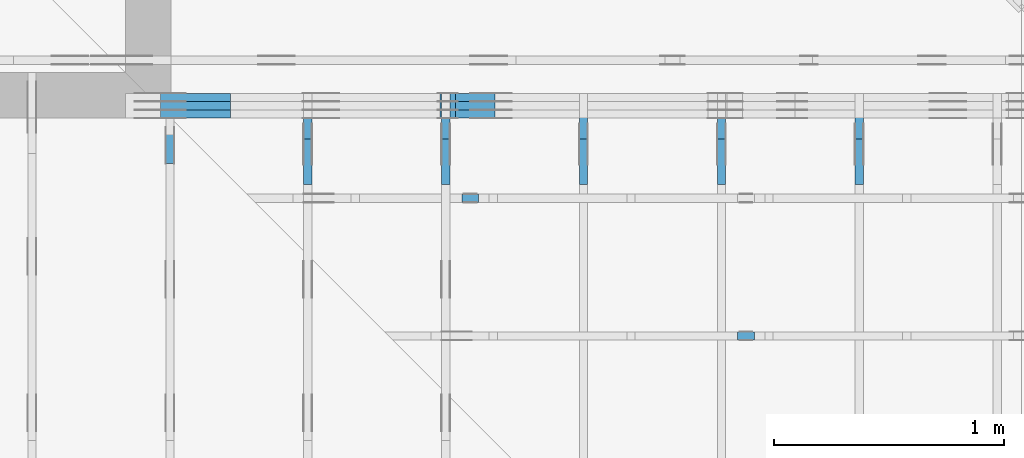
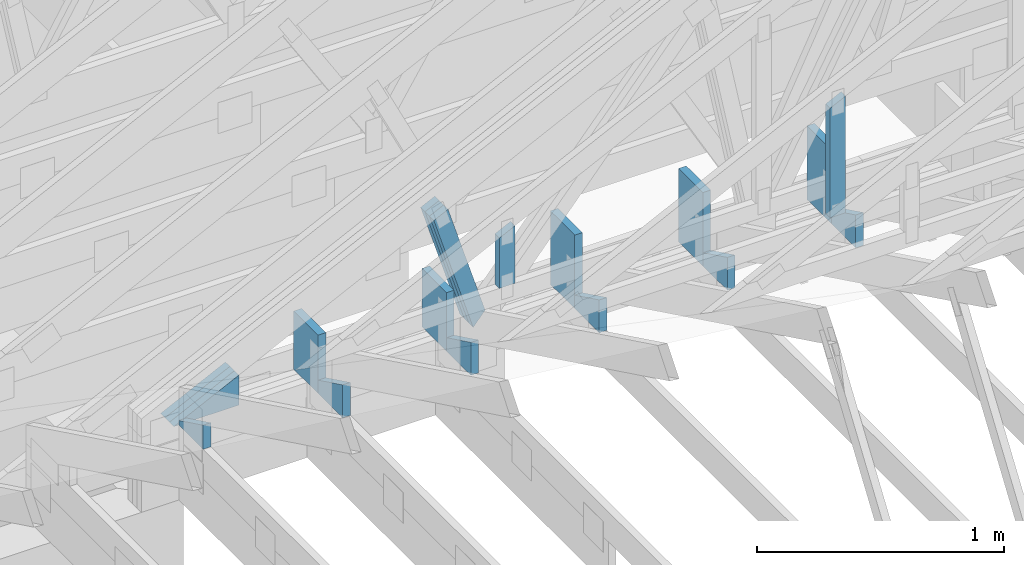
# One storey, part 45 of 159: 19 members, 9 elements without a shape of their own.
"""IFC2X3 building model written with IfcOpenShell, lengths in millimetres."""

from ifc_helpers import new_model, si_unit, frame, origin, origin_with_axes, origin_2d, place, context, project, spatial, faceted_brep, element, aggregate, save


model = new_model("IFC2X3")

# Units and contexts
model_context = context("Model", 3, precision=1e-05, world=origin())
plan_context = context("Plan", 2, precision=1e-05, world=origin_2d())
ifc_project = project(units=[si_unit("LENGTHUNIT", "METRE", prefix="MILLI"), si_unit("AREAUNIT", "SQUARE_METRE"), si_unit("VOLUMEUNIT", "CUBIC_METRE"), si_unit("SOLIDANGLEUNIT", "STERADIAN"), si_unit("PLANEANGLEUNIT", "RADIAN"), si_unit("MASSUNIT", "GRAM"), si_unit("TIMEUNIT", "SECOND"), si_unit("THERMODYNAMICTEMPERATUREUNIT", "DEGREE_CELSIUS"), si_unit("LUMINOUSINTENSITYUNIT", "LUMEN")], contexts=[model_context, plan_context])

# Site, building, storey
site_placement = place(None, origin_with_axes())
site = spatial("IfcSite", under=ifc_project, at=site_placement, CompositionType="ELEMENT")
building_placement = place(site_placement, origin_with_axes())
building = spatial("IfcBuilding", under=site, at=building_placement, Name="Plan 1", CompositionType="ELEMENT")
storey_placement = place(building_placement, origin_with_axes())
storey = spatial("IfcBuildingStorey", under=building, at=storey_placement, Name="Etasje 1", CompositionType="ELEMENT", Elevation=0.0)

# Assembly, members
assembly_1_placement = place(storey_placement, frame((10700.012663101485, 8801.999999990367, 0.0), z_axis=(0.0, -1.0, 6.123031769111886e-17), x_axis=(1.0, 0.0, 0.0)))
assembly_1 = element("IfcElementAssembly", 1, at=assembly_1_placement, inside=storey, Name="T8 (1)", AssemblyPlace="FACTORY", PredefinedType="TRUSS")
member_1_placement = place(assembly_1_placement, frame((152.23972507752478, 371.0, -36.0), z_axis=(0.0, 0.0, 1.0), x_axis=(1.0, 0.0, 0.0)))
member_1 = element("IfcMember", 2, at=member_1_placement, Name="T8-KI4", context=model_context, shape_type="Brep", body=[
    faceted_brep([(303.4449673052877, 148.0, 36.0), (5.757436156272888e-06, 0.0, 36.0), (303.4449673052877, 0.0, 36.0), (303.4449673052877, 148.0, 0.0), (303.4449673052877, 0.0, 0.0), (5.757436156272888e-06, 0.0, 0.0), (0.0, 0.0, 0.0), (9.662977650426896e-16, -1.9812040197761635e-15, 36.0), (303.444968553682, 147.99999999999997, 36.0), (303.444968553682, 147.99999999999997, -2.6180736086187996e-30), (303.4449685537356, -5.574009547895041e-14, 3.412983754309432e-30), (303.4449685537356, -5.353580404207013e-14, 36.0), (4.049083948919771e-31, 2.204291436880279e-15, 36.0), (0.0, 0.0, 0.0), (303.4449685537356, 148.0, 3.281661365719409e-27), (303.4449685537356, 148.0, 36.0), (303.4449685537356, 0.0, 36.0), (303.4449685537356, 0.0, 0.0)], [[[0, 1, 2]], [[3, 4, 5]], [[6, 7, 8, 9]], [[10, 11, 12, 13]], [[14, 15, 16, 17]]]),
])
member_2_placement = place(assembly_1_placement, frame((152.23972507752478, 371.0, -72.0), z_axis=(0.0, 0.0, 1.0), x_axis=(1.0, 0.0, 0.0)))
member_2 = element("IfcMember", 3, at=member_2_placement, Name="T8-KI4", context=model_context, shape_type="Brep", body=[
    faceted_brep([(303.4449673052877, 148.0, 36.0), (5.757436156272888e-06, 0.0, 36.0), (303.4449673052877, 0.0, 36.0), (303.4449673052877, 148.0, 0.0), (303.4449673052877, 0.0, 0.0), (5.757436156272888e-06, 0.0, 0.0), (0.0, 0.0, 0.0), (9.662977650426896e-16, -1.9812040197761635e-15, 36.0), (303.444968553682, 147.99999999999997, 36.0), (303.444968553682, 147.99999999999997, -2.6180736086187996e-30), (303.4449685537356, -5.574009547895041e-14, 3.412983754309432e-30), (303.4449685537356, -5.353580404207013e-14, 36.0), (4.049083948919771e-31, 2.204291436880279e-15, 36.0), (0.0, 0.0, 0.0), (303.4449685537356, 148.0, 3.281661365719409e-27), (303.4449685537356, 148.0, 36.0), (303.4449685537356, 0.0, 36.0), (303.4449685537356, 0.0, 0.0)], [[[0, 1, 2]], [[3, 4, 5]], [[6, 7, 8, 9]], [[10, 11, 12, 13]], [[14, 15, 16, 17]]]),
])
member_3_placement = place(assembly_1_placement, frame((152.23972507752478, 371.0, -108.0), z_axis=(0.0, 0.0, 1.0), x_axis=(1.0, 0.0, 0.0)))
member_3 = element("IfcMember", 4, at=member_3_placement, Name="T8-KI4", context=model_context, shape_type="Brep", body=[
    faceted_brep([(303.4449673052877, 148.0, 36.0), (5.757436156272888e-06, 0.0, 36.0), (303.4449673052877, 0.0, 36.0), (303.4449673052877, 148.0, 0.0), (303.4449673052877, 0.0, 0.0), (5.757436156272888e-06, 0.0, 0.0), (0.0, 0.0, 0.0), (9.662977650426896e-16, -1.9812040197761635e-15, 36.0), (303.444968553682, 147.99999999999997, 36.0), (303.444968553682, 147.99999999999997, -2.6180736086187996e-30), (303.4449685537356, -5.574009547895041e-14, 3.412983754309432e-30), (303.4449685537356, -5.353580404207013e-14, 36.0), (4.049083948919771e-31, 2.204291436880279e-15, 36.0), (0.0, 0.0, 0.0), (303.4449685537356, 148.0, 3.281661365719409e-27), (303.4449685537356, 148.0, 36.0), (303.4449685537356, 0.0, 36.0), (303.4449685537356, 0.0, 0.0)], [[[0, 1, 2]], [[3, 4, 5]], [[6, 7, 8, 9]], [[10, 11, 12, 13]], [[14, 15, 16, 17]]]),
])
member_4_placement = place(assembly_1_placement, frame((1364.9619327312275, 974.8732628505372, -36.00000000000001), z_axis=(0.0, 0.0, 1.0), x_axis=(0.2961414573045144, -0.9551440924099143, 0.0)))
member_4 = element("IfcMember", 5, at=member_4_placement, Name="T8-D67", context=model_context, shape_type="Brep", body=[
    faceted_brep([(585.6447533994713, 73.00007706554379, 36.0), (3.7655692040061695e-06, 73.00007706554379, 36.0), (11.2670859511461, 0.0, 36.0), (632.2326779148378, 0.0, 36.0), (3.7655692040061695e-06, 73.00007706554379, 4.611339972983827e-22), (585.6447533994713, 73.00007706554379, 7.171842860957318e-14), (632.2326779148378, 0.0, 7.74236154468647e-14), (11.2670859511461, 0.0, 1.3797745044836358e-15), (11.26711467820826, 3.2846568956523825e-05, -9.860761315262648e-32), (11.267114678208262, 3.2846568956967914e-05, 36.0), (3.197442310920451e-14, 73.00023531536866, 36.0), (3.019806626980426e-14, 73.00023531536866, -1.9721522630525295e-30), (632.2326729089058, 0.00013408096902131113, 2.771038273103004e-29), (632.2326729089058, 0.00013408096902351542, 36.0), (11.26711467820826, 3.2846568950440936e-05, 36.0), (11.26711467820826, 3.2846568948236644e-05, 4.938306310742308e-31), (585.644755694868, 73.00013408096831, 6.310887241768095e-30), (585.644755694868, 73.00013408096831, 36.0), (632.2326729089058, 0.00013408096947387094, 36.0), (632.2326729089058, 0.00013408096947387094, 0.0), (0.0, 73.00023531536863, 1.8541662651750408e-44), (0.0, 73.00023531536863, 36.0), (585.644755694868, 73.00013408096848, 36.0), (585.644755694868, 73.00013408096848, 8.677469096903521e-30)], [[[0, 1, 2, 3]], [[4, 5, 6, 7]], [[8, 9, 10, 11]], [[12, 13, 14, 15]], [[16, 17, 18, 19]], [[20, 21, 22, 23]]]),
])
member_5_placement = place(assembly_1_placement, frame((1364.9619327312275, 974.8732628505372, -72.00000000000001), z_axis=(0.0, 0.0, 1.0), x_axis=(0.2961414573045144, -0.9551440924099143, 0.0)))
member_5 = element("IfcMember", 6, at=member_5_placement, Name="T8-D67", context=model_context, shape_type="Brep", body=[
    faceted_brep([(585.6447533994713, 73.00007706554379, 36.0), (3.7655692040061695e-06, 73.00007706554379, 36.0), (11.2670859511461, 0.0, 36.0), (632.2326779148378, 0.0, 36.0), (3.7655692040061695e-06, 73.00007706554379, 4.611339972983827e-22), (585.6447533994713, 73.00007706554379, 7.171842860957318e-14), (632.2326779148378, 0.0, 7.74236154468647e-14), (11.2670859511461, 0.0, 1.3797745044836358e-15), (11.26711467820826, 3.2846568956523825e-05, -9.860761315262648e-32), (11.267114678208262, 3.2846568956967914e-05, 36.0), (3.197442310920451e-14, 73.00023531536866, 36.0), (3.019806626980426e-14, 73.00023531536866, -1.9721522630525295e-30), (632.2326729089058, 0.00013408096902131113, 2.771038273103004e-29), (632.2326729089058, 0.00013408096902351542, 36.0), (11.26711467820826, 3.2846568950440936e-05, 36.0), (11.26711467820826, 3.2846568948236644e-05, 4.938306310742308e-31), (585.644755694868, 73.00013408096831, 6.310887241768095e-30), (585.644755694868, 73.00013408096831, 36.0), (632.2326729089058, 0.00013408096947387094, 36.0), (632.2326729089058, 0.00013408096947387094, 0.0), (0.0, 73.00023531536863, 1.8541662651750408e-44), (0.0, 73.00023531536863, 36.0), (585.644755694868, 73.00013408096848, 36.0), (585.644755694868, 73.00013408096848, 8.677469096903521e-30)], [[[0, 1, 2, 3]], [[4, 5, 6, 7]], [[8, 9, 10, 11]], [[12, 13, 14, 15]], [[16, 17, 18, 19]], [[20, 21, 22, 23]]]),
])
member_6_placement = place(assembly_1_placement, frame((1364.9619327312275, 974.8732628505372, -108.00000000000001), z_axis=(0.0, 0.0, 1.0), x_axis=(0.2961414573045144, -0.9551440924099143, 0.0)))
member_6 = element("IfcMember", 7, at=member_6_placement, Name="T8-D67", context=model_context, shape_type="Brep", body=[
    faceted_brep([(585.6447533994713, 73.00007706554379, 36.0), (3.7655692040061695e-06, 73.00007706554379, 36.0), (11.2670859511461, 0.0, 36.0), (632.2326779148378, 0.0, 36.0), (3.7655692040061695e-06, 73.00007706554379, 4.611339972983827e-22), (585.6447533994713, 73.00007706554379, 7.171842860957318e-14), (632.2326779148378, 0.0, 7.74236154468647e-14), (11.2670859511461, 0.0, 1.3797745044836358e-15), (11.26711467820826, 3.2846568956523825e-05, -9.860761315262648e-32), (11.267114678208262, 3.2846568956967914e-05, 36.0), (3.197442310920451e-14, 73.00023531536866, 36.0), (3.019806626980426e-14, 73.00023531536866, -1.9721522630525295e-30), (632.2326729089058, 0.00013408096902131113, 2.771038273103004e-29), (632.2326729089058, 0.00013408096902351542, 36.0), (11.26711467820826, 3.2846568950440936e-05, 36.0), (11.26711467820826, 3.2846568948236644e-05, 4.938306310742308e-31), (585.644755694868, 73.00013408096831, 6.310887241768095e-30), (585.644755694868, 73.00013408096831, 36.0), (632.2326729089058, 0.00013408096947387094, 36.0), (632.2326729089058, 0.00013408096947387094, 0.0), (0.0, 73.00023531536863, 1.8541662651750408e-44), (0.0, 73.00023531536863, 36.0), (585.644755694868, 73.00013408096848, 36.0), (585.644755694868, 73.00013408096848, 8.677469096903521e-30)], [[[0, 1, 2, 3]], [[4, 5, 6, 7]], [[8, 9, 10, 11]], [[12, 13, 14, 15]], [[16, 17, 18, 19]], [[20, 21, 22, 23]]]),
])
aggregate(assembly_1, [member_1, member_2, member_3, member_4, member_5, member_6])

assembly_2_placement = place(storey_placement, frame((13875.022261404752, -699.9989301294836, 1.1021457184401395e-15), z_axis=(-1.0, 1.836909530733566e-16, 6.123031769111886e-17), x_axis=(-1.836909530733566e-16, -1.0, 0.0)))
assembly_2 = element("IfcElementAssembly", 8, at=assembly_2_placement, inside=storey, Name="T6 (101)", AssemblyPlace="FACTORY", PredefinedType="TRUSS")
member_7_placement = place(assembly_2_placement, frame((-9411.99893013318, 371.0, -36.0), z_axis=(0.0, 0.0, 1.0), x_axis=(-2.6074085653169515e-12, 1.0, 0.0)))
member_7 = element("IfcMember", 9, at=member_7_placement, Name="T6-S1", context=model_context, shape_type="Brep", body=[
    faceted_brep([(363.47723388723495, 198.0000933033716, 36.0), (5.162519300938584e-10, 198.0000933033716, 36.0), (0.0, 9.330431930720806e-05, 36.0), (363.4772338867187, 9.330431930720806e-05, 36.0), (5.162519300938584e-10, 198.0000933033716, 6.322053937660047e-26), (363.47723388723495, 198.0000933033716, 4.4511653008809024e-14), (363.4772338867187, 9.330431930720806e-05, 4.45116530087458e-14), (0.0, 9.330431930720806e-05, 0.0), (0.0, 0.0, 0.0), (2.204291436880279e-15, -5.7474038303501e-27, 36.0), (5.162615062011267e-10, 198.0, 36.0), (5.162593019096898e-10, 198.0, -4.513786253158592e-31), (363.47721516495375, 6.308078123434283e-08, -2.921223515766118e-30), (363.47721516495375, 6.308078343863427e-08, 36.0), (-3.825505976859566e-25, 2.204291436880279e-15, 36.0), (0.0, 0.0, 0.0), (363.47721516495375, 198.0000000612181, -3.16080787503955e-26), (363.47721516495375, 198.0000000612181, 36.0), (363.47721516495375, 6.308073352556676e-08, 36.0), (363.47721516495375, 6.308073352556676e-08, 0.0), (5.162519300938584e-10, 198.0, 0.0), (5.162519300938584e-10, 198.0, 36.0), (363.47721516547, 198.0000000612181, 36.0), (363.47721516547, 198.0000000612181, -1.5777218104420236e-30)], [[[0, 1, 2, 3]], [[4, 5, 6, 7]], [[8, 9, 10, 11]], [[12, 13, 14, 15]], [[16, 17, 18, 19]], [[20, 21, 22, 23]]]),
])
member_8_placement = place(assembly_2_placement, frame((-9213.998930133188, 371.0, -36.0), z_axis=(0.0, 0.0, 1.0), x_axis=(-1.7615569541788202e-10, 1.0, 0.0)))
member_8 = element("IfcMember", 10, at=member_8_placement, Name="T6-S5", context=model_context, shape_type="Brep", body=[
    faceted_brep([(66.21466067941009, 198.00009329264867, 36.0), (3.4878837595897494e-08, 198.00009329264867, 36.0), (0.0, 9.330431203125045e-05, 36.0), (162.7857055664063, 9.330431203125045e-05, 36.0), (3.4878837595897494e-08, 198.00009329264867, 4.271284613387488e-24), (66.21466067941009, 198.00009329264867, 8.108689418419832e-15), (162.7857055664063, 9.330431203125045e-05, 1.9934840934807988e-14), (0.0, 9.330431203125045e-05, 0.0), (-2.605355528885784e-24, 6.255140760913491e-08, 1.5952674669991638e-40), (2.2042914342749235e-15, 6.255140760913491e-08, 36.0), (3.487882230300644e-08, 198.00000006253686, 36.0), (3.4878820098715006e-08, 198.00000006253686, 1.071358042460672e-30), (162.78571493316844, -3.9667248731015275e-14, 2.4288382424236155e-30), (162.78571493316844, -3.7462957294134996e-14, 36.0), (8.470130163630552e-25, 6.255140981342635e-08, 36.0), (0.0, 6.255140760913491e-08, 0.0), (66.21466011511593, 198.0, 0.0), (66.21466011511593, 198.0, 36.0), (162.78571493316844, 1.4210854715202004e-14, 36.0), (162.78571493316846, 1.4210854715202004e-14, 1.5777218104420236e-30), (3.4878837595897494e-08, 198.00000006253686, 0.0), (3.4878837595897494e-08, 198.00000006253686, 36.0), (66.21466011511592, 198.0, 36.0), (66.21466011511592, 198.0, 0.0)], [[[0, 1, 2, 3]], [[4, 5, 6, 7]], [[8, 9, 10, 11]], [[12, 13, 14, 15]], [[16, 17, 18, 19]], [[20, 21, 22, 23]]]),
])
aggregate(assembly_2, [member_7, member_8])

assembly_3_placement = place(storey_placement, frame((13275.022261404752, -699.9989301294836, 1.1021457184401395e-15), z_axis=(-1.0, 1.836909530733566e-16, 6.123031769111886e-17), x_axis=(-1.836909530733566e-16, -1.0, 0.0)))
assembly_3 = element("IfcElementAssembly", 11, at=assembly_3_placement, inside=storey, Name="T6 (100)", AssemblyPlace="FACTORY", PredefinedType="TRUSS")
member_9_placement = place(assembly_3_placement, frame((-9411.99893013318, 371.0, -36.0), z_axis=(0.0, 0.0, 1.0), x_axis=(-2.6074085653169515e-12, 1.0, 0.0)))
member_9 = element("IfcMember", 12, at=member_9_placement, Name="T6-S1", context=model_context, shape_type="Brep", body=[
    faceted_brep([(363.47723388723495, 198.0000933033716, 36.0), (5.162519300938584e-10, 198.0000933033716, 36.0), (0.0, 9.330431930720806e-05, 36.0), (363.4772338867187, 9.330431930720806e-05, 36.0), (5.162519300938584e-10, 198.0000933033716, 6.322053937660047e-26), (363.47723388723495, 198.0000933033716, 4.4511653008809024e-14), (363.4772338867187, 9.330431930720806e-05, 4.45116530087458e-14), (0.0, 9.330431930720806e-05, 0.0), (0.0, 0.0, 0.0), (2.204291436880279e-15, -5.7474038303501e-27, 36.0), (5.162615062011267e-10, 198.0, 36.0), (5.162593019096898e-10, 198.0, -4.513786253158592e-31), (363.47721516495375, 6.308078123434283e-08, -2.921223515766118e-30), (363.47721516495375, 6.308078343863427e-08, 36.0), (-3.825505976859566e-25, 2.204291436880279e-15, 36.0), (0.0, 0.0, 0.0), (363.47721516495375, 198.0000000612181, -3.16080787503955e-26), (363.47721516495375, 198.0000000612181, 36.0), (363.47721516495375, 6.308073352556676e-08, 36.0), (363.47721516495375, 6.308073352556676e-08, 0.0), (5.162519300938584e-10, 198.0, 0.0), (5.162519300938584e-10, 198.0, 36.0), (363.47721516547, 198.0000000612181, 36.0), (363.47721516547, 198.0000000612181, -1.5777218104420236e-30)], [[[0, 1, 2, 3]], [[4, 5, 6, 7]], [[8, 9, 10, 11]], [[12, 13, 14, 15]], [[16, 17, 18, 19]], [[20, 21, 22, 23]]]),
])
member_10_placement = place(assembly_3_placement, frame((-9213.998930133188, 371.0, -36.0), z_axis=(0.0, 0.0, 1.0), x_axis=(-1.7615569541788202e-10, 1.0, 0.0)))
member_10 = element("IfcMember", 13, at=member_10_placement, Name="T6-S5", context=model_context, shape_type="Brep", body=[
    faceted_brep([(66.21466067941009, 198.00009329264867, 36.0), (3.4878837595897494e-08, 198.00009329264867, 36.0), (0.0, 9.330431203125045e-05, 36.0), (162.7857055664063, 9.330431203125045e-05, 36.0), (3.4878837595897494e-08, 198.00009329264867, 4.271284613387488e-24), (66.21466067941009, 198.00009329264867, 8.108689418419832e-15), (162.7857055664063, 9.330431203125045e-05, 1.9934840934807988e-14), (0.0, 9.330431203125045e-05, 0.0), (-2.605355528885784e-24, 6.255140760913491e-08, 1.5952674669991638e-40), (2.2042914342749235e-15, 6.255140760913491e-08, 36.0), (3.487882230300644e-08, 198.00000006253686, 36.0), (3.4878820098715006e-08, 198.00000006253686, 1.071358042460672e-30), (162.78571493316844, -3.9667248731015275e-14, 2.4288382424236155e-30), (162.78571493316844, -3.7462957294134996e-14, 36.0), (8.470130163630552e-25, 6.255140981342635e-08, 36.0), (0.0, 6.255140760913491e-08, 0.0), (66.21466011511593, 198.0, 0.0), (66.21466011511593, 198.0, 36.0), (162.78571493316844, 1.4210854715202004e-14, 36.0), (162.78571493316846, 1.4210854715202004e-14, 1.5777218104420236e-30), (3.4878837595897494e-08, 198.00000006253686, 0.0), (3.4878837595897494e-08, 198.00000006253686, 36.0), (66.21466011511592, 198.0, 36.0), (66.21466011511592, 198.0, 0.0)], [[[0, 1, 2, 3]], [[4, 5, 6, 7]], [[8, 9, 10, 11]], [[12, 13, 14, 15]], [[16, 17, 18, 19]], [[20, 21, 22, 23]]]),
])
aggregate(assembly_3, [member_9, member_10])

assembly_4_placement = place(storey_placement, frame((12675.022261404752, -699.9989301294854, 4.558494966049043e-13), z_axis=(-1.0, 1.836909530733566e-16, 6.123031769111886e-17), x_axis=(-1.836909530733566e-16, -1.0, 0.0)))
assembly_4 = element("IfcElementAssembly", 14, at=assembly_4_placement, inside=storey, Name="T6 (99)", AssemblyPlace="FACTORY", PredefinedType="TRUSS")
member_11_placement = place(assembly_4_placement, frame((-9411.99893013318, 371.0, -36.0), z_axis=(0.0, 0.0, 1.0), x_axis=(-2.6074085653169515e-12, 1.0, 0.0)))
member_11 = element("IfcMember", 15, at=member_11_placement, Name="T6-S1", context=model_context, shape_type="Brep", body=[
    faceted_brep([(363.47723388723495, 198.0000933033716, 36.0), (5.162519300938584e-10, 198.0000933033716, 36.0), (0.0, 9.330431930720806e-05, 36.0), (363.4772338867187, 9.330431930720806e-05, 36.0), (5.162519300938584e-10, 198.0000933033716, 6.322053937660047e-26), (363.47723388723495, 198.0000933033716, 4.4511653008809024e-14), (363.4772338867187, 9.330431930720806e-05, 4.45116530087458e-14), (0.0, 9.330431930720806e-05, 0.0), (0.0, 0.0, 0.0), (2.204291436880279e-15, -5.7474038303501e-27, 36.0), (5.162615062011267e-10, 198.0, 36.0), (5.162593019096898e-10, 198.0, -4.513786253158592e-31), (363.47721516495375, 6.308078123434283e-08, -2.921223515766118e-30), (363.47721516495375, 6.308078343863427e-08, 36.0), (-3.825505976859566e-25, 2.204291436880279e-15, 36.0), (0.0, 0.0, 0.0), (363.47721516495375, 198.0000000612181, -3.16080787503955e-26), (363.47721516495375, 198.0000000612181, 36.0), (363.47721516495375, 6.308073352556676e-08, 36.0), (363.47721516495375, 6.308073352556676e-08, 0.0), (5.162519300938584e-10, 198.0, 0.0), (5.162519300938584e-10, 198.0, 36.0), (363.47721516547, 198.0000000612181, 36.0), (363.47721516547, 198.0000000612181, -1.5777218104420236e-30)], [[[0, 1, 2, 3]], [[4, 5, 6, 7]], [[8, 9, 10, 11]], [[12, 13, 14, 15]], [[16, 17, 18, 19]], [[20, 21, 22, 23]]]),
])
member_12_placement = place(assembly_4_placement, frame((-9213.998930133188, 371.0, -36.0), z_axis=(0.0, 0.0, 1.0), x_axis=(-1.7615569541788202e-10, 1.0, 0.0)))
member_12 = element("IfcMember", 16, at=member_12_placement, Name="T6-S5", context=model_context, shape_type="Brep", body=[
    faceted_brep([(66.21466067941009, 198.00009329264867, 36.0), (3.4878837595897494e-08, 198.00009329264867, 36.0), (0.0, 9.330431203125045e-05, 36.0), (162.7857055664063, 9.330431203125045e-05, 36.0), (3.4878837595897494e-08, 198.00009329264867, 4.271284613387488e-24), (66.21466067941009, 198.00009329264867, 8.108689418419832e-15), (162.7857055664063, 9.330431203125045e-05, 1.9934840934807988e-14), (0.0, 9.330431203125045e-05, 0.0), (-2.605355528885784e-24, 6.255140760913491e-08, 1.5952674669991638e-40), (2.2042914342749235e-15, 6.255140760913491e-08, 36.0), (3.487882230300644e-08, 198.00000006253686, 36.0), (3.4878820098715006e-08, 198.00000006253686, 1.071358042460672e-30), (162.78571493316844, -3.9667248731015275e-14, 2.4288382424236155e-30), (162.78571493316844, -3.7462957294134996e-14, 36.0), (8.470130163630552e-25, 6.255140981342635e-08, 36.0), (0.0, 6.255140760913491e-08, 0.0), (66.21466011511593, 198.0, 0.0), (66.21466011511593, 198.0, 36.0), (162.78571493316844, 1.4210854715202004e-14, 36.0), (162.78571493316846, 1.4210854715202004e-14, 1.5777218104420236e-30), (3.4878837595897494e-08, 198.00000006253686, 0.0), (3.4878837595897494e-08, 198.00000006253686, 36.0), (66.21466011511592, 198.0, 36.0), (66.21466011511592, 198.0, 0.0)], [[[0, 1, 2, 3]], [[4, 5, 6, 7]], [[8, 9, 10, 11]], [[12, 13, 14, 15]], [[16, 17, 18, 19]], [[20, 21, 22, 23]]]),
])
aggregate(assembly_4, [member_11, member_12])

assembly_5_placement = place(storey_placement, frame((12075.022261404752, -699.9989301294854, 4.558494966049043e-13), z_axis=(-1.0, 1.836909530733566e-16, 6.123031769111886e-17), x_axis=(-1.836909530733566e-16, -1.0, 0.0)))
assembly_5 = element("IfcElementAssembly", 17, at=assembly_5_placement, inside=storey, Name="T5 (98)", AssemblyPlace="FACTORY", PredefinedType="TRUSS")
member_13_placement = place(assembly_5_placement, frame((-9411.99893013318, 371.0, -36.0), z_axis=(0.0, 0.0, 1.0), x_axis=(-2.604077896243076e-12, 1.0, 0.0)))
member_13 = element("IfcMember", 18, at=member_13_placement, Name="T5-S2", context=model_context, shape_type="Brep", body=[
    faceted_brep([(288.4772338872344, 198.00009330356806, 36.0), (5.156266524863895e-10, 198.00009330356806, 36.0), (0.0, 9.330431930720806e-05, 36.0), (288.4772338867188, 9.330431930720806e-05, 36.0), (5.156266524863895e-10, 198.00009330356806, 6.314396748349955e-26), (288.4772338872344, 198.00009330356806, 3.5327105355141125e-14), (288.4772338867188, 9.330431930720806e-05, 3.5327105355077984e-14), (0.0, 9.330431930720806e-05, 0.0), (0.0, 0.0, 0.0), (2.204291436880279e-15, -5.7405515160527164e-27, 36.0), (5.156459985562745e-10, 198.0, 36.0), (5.156437942648376e-10, 198.0, -1.0495965401668395e-30), (288.4772151652724, 6.327687467680156e-08, 1.8963295627508278e-29), (288.4772151652724, 6.3276876881093e-08, 36.0), (-4.835067231313569e-25, 2.204291436880279e-15, 36.0), (0.0, 0.0, 0.0), (288.4772151652724, 198.00000006141454, -3.157021342694489e-26), (288.4772151652724, 198.00000006141454, 36.0), (288.4772151652724, 6.327718438114971e-08, 36.0), (288.4772151652724, 6.327718438114971e-08, 0.0), (5.156266524863895e-10, 198.0, 0.0), (5.156266524863895e-10, 198.0, 36.0), (288.477215165788, 198.0000000614145, 36.0), (288.477215165788, 198.0000000614145, -1.5777218104420236e-30)], [[[0, 1, 2, 3]], [[4, 5, 6, 7]], [[8, 9, 10, 11]], [[12, 13, 14, 15]], [[16, 17, 18, 19]], [[20, 21, 22, 23]]]),
])
member_14_placement = place(assembly_5_placement, frame((-9213.998930125732, 371.0, -36.0), z_axis=(0.0, 0.0, 1.0), x_axis=(-2.2195350540669435e-10, 1.0, 0.0)))
member_14 = element("IfcMember", 19, at=member_14_placement, Name="T5-S5", context=model_context, shape_type="Brep", body=[
    faceted_brep([(66.21466068847803, 198.00009329707245, 36.0), (4.394678398966789e-08, 198.00009329707245, 36.0), (0.0, 9.331176806881558e-05, 36.0), (162.7857055664062, 9.331176806881558e-05, 36.0), (4.394678398966789e-08, 198.00009329707245, 5.381751090380682e-24), (66.21466068847803, 198.00009329707245, 8.108689419530299e-15), (162.7857055664062, 9.331176806881558e-05, 1.9934840934807976e-14), (0.0, 9.331176806881558e-05, 0.0), (-1.6269727140338805e-23, 7.000744517426938e-08, 9.962005615053268e-40), (2.204291420610552e-15, 7.000744517426938e-08, 36.0), (4.394674471595883e-08, 198.0000000699929, 36.0), (4.394674251166739e-08, 198.0000000699929, 2.5397111477054943e-30), (162.78571493316844, 9.596998555046498e-15, -5.876272705792561e-31), (162.78571493316844, 1.1801289991926777e-14, 36.0), (9.479750187836808e-25, 7.000744737856082e-08, 36.0), (0.0, 7.000744517426938e-08, 0.0), (66.21466012418387, 198.0000000044238, 0.0), (66.21466012418387, 198.0000000044238, 36.0), (162.78571493316846, -2.842170943040401e-14, 36.0), (162.78571493316846, -2.842170943040401e-14, 0.0), (4.394678398966789e-08, 198.0000000699929, 0.0), (4.394678398966789e-08, 198.0000000699929, 36.0), (66.21466012418387, 198.00000000442378, 36.0), (66.21466012418387, 198.00000000442378, 0.0)], [[[0, 1, 2, 3]], [[4, 5, 6, 7]], [[8, 9, 10, 11]], [[12, 13, 14, 15]], [[16, 17, 18, 19]], [[20, 21, 22, 23]]]),
])
aggregate(assembly_5, [member_13, member_14])

assembly_6_placement = place(storey_placement, frame((11475.022261404752, -699.9989301294845, 1.1021457184401395e-15), z_axis=(-1.0, 1.836909530733566e-16, 6.123031769111886e-17), x_axis=(-1.836909530733566e-16, -1.0, 0.0)))
assembly_6 = element("IfcElementAssembly", 20, at=assembly_6_placement, inside=storey, Name="T5 (97)", AssemblyPlace="FACTORY", PredefinedType="TRUSS")
member_15_placement = place(assembly_6_placement, frame((-9411.99893013318, 371.0, -36.0), z_axis=(0.0, 0.0, 1.0), x_axis=(-2.604077896243076e-12, 1.0, 0.0)))
member_15 = element("IfcMember", 21, at=member_15_placement, Name="T5-S2", context=model_context, shape_type="Brep", body=[
    faceted_brep([(288.4772338872344, 198.00009330356806, 36.0), (5.156266524863895e-10, 198.00009330356806, 36.0), (0.0, 9.330431930720806e-05, 36.0), (288.4772338867188, 9.330431930720806e-05, 36.0), (5.156266524863895e-10, 198.00009330356806, 6.314396748349955e-26), (288.4772338872344, 198.00009330356806, 3.5327105355141125e-14), (288.4772338867188, 9.330431930720806e-05, 3.5327105355077984e-14), (0.0, 9.330431930720806e-05, 0.0), (0.0, 0.0, 0.0), (2.204291436880279e-15, -5.7405515160527164e-27, 36.0), (5.156459985562745e-10, 198.0, 36.0), (5.156437942648376e-10, 198.0, -1.0495965401668395e-30), (288.4772151652724, 6.327687467680156e-08, 1.8963295627508278e-29), (288.4772151652724, 6.3276876881093e-08, 36.0), (-4.835067231313569e-25, 2.204291436880279e-15, 36.0), (0.0, 0.0, 0.0), (288.4772151652724, 198.00000006141454, -3.157021342694489e-26), (288.4772151652724, 198.00000006141454, 36.0), (288.4772151652724, 6.327718438114971e-08, 36.0), (288.4772151652724, 6.327718438114971e-08, 0.0), (5.156266524863895e-10, 198.0, 0.0), (5.156266524863895e-10, 198.0, 36.0), (288.477215165788, 198.0000000614145, 36.0), (288.477215165788, 198.0000000614145, -1.5777218104420236e-30)], [[[0, 1, 2, 3]], [[4, 5, 6, 7]], [[8, 9, 10, 11]], [[12, 13, 14, 15]], [[16, 17, 18, 19]], [[20, 21, 22, 23]]]),
])
member_16_placement = place(assembly_6_placement, frame((-9213.998930125732, 371.0, -36.0), z_axis=(0.0, 0.0, 1.0), x_axis=(-2.2195350540669435e-10, 1.0, 0.0)))
member_16 = element("IfcMember", 22, at=member_16_placement, Name="T5-S5", context=model_context, shape_type="Brep", body=[
    faceted_brep([(66.21466068847803, 198.00009329707245, 36.0), (4.394678398966789e-08, 198.00009329707245, 36.0), (0.0, 9.331176806881558e-05, 36.0), (162.7857055664062, 9.331176806881558e-05, 36.0), (4.394678398966789e-08, 198.00009329707245, 5.381751090380682e-24), (66.21466068847803, 198.00009329707245, 8.108689419530299e-15), (162.7857055664062, 9.331176806881558e-05, 1.9934840934807976e-14), (0.0, 9.331176806881558e-05, 0.0), (-1.6269727140338805e-23, 7.000744517426938e-08, 9.962005615053268e-40), (2.204291420610552e-15, 7.000744517426938e-08, 36.0), (4.394674471595883e-08, 198.0000000699929, 36.0), (4.394674251166739e-08, 198.0000000699929, 2.5397111477054943e-30), (162.78571493316844, 9.596998555046498e-15, -5.876272705792561e-31), (162.78571493316844, 1.1801289991926777e-14, 36.0), (9.479750187836808e-25, 7.000744737856082e-08, 36.0), (0.0, 7.000744517426938e-08, 0.0), (66.21466012418387, 198.0000000044238, 0.0), (66.21466012418387, 198.0000000044238, 36.0), (162.78571493316846, -2.842170943040401e-14, 36.0), (162.78571493316846, -2.842170943040401e-14, 0.0), (4.394678398966789e-08, 198.0000000699929, 0.0), (4.394678398966789e-08, 198.0000000699929, 36.0), (66.21466012418387, 198.00000000442378, 36.0), (66.21466012418387, 198.00000000442378, 0.0)], [[[0, 1, 2, 3]], [[4, 5, 6, 7]], [[8, 9, 10, 11]], [[12, 13, 14, 15]], [[16, 17, 18, 19]], [[20, 21, 22, 23]]]),
])
aggregate(assembly_6, [member_15, member_16])

# Assembly, member
assembly_7_placement = place(storey_placement, frame((10875.02226140475, -699.9989301294845, 1.1021457184401395e-15), z_axis=(-1.0, 1.836909530733566e-16, 6.123031769111886e-17), x_axis=(-1.836909530733566e-16, -1.0, 0.0)))
assembly_7 = element("IfcElementAssembly", 23, at=assembly_7_placement, inside=storey, Name="T4 (96)", AssemblyPlace="FACTORY", PredefinedType="TRUSS")
member_17_placement = place(assembly_7_placement, frame((-9303.998930048427, 371.0, -36.0), z_axis=(0.0, 0.0, 1.0), x_axis=(-2.6082967437366517e-12, 1.0, 0.0)))
member_17 = element("IfcMember", 24, at=member_17_placement, Name="T4-S6", context=model_context, shape_type="Brep", body=[
    faceted_brep([(22.318786621610172, 198.0000933890151, 36.0), (5.164224603504408e-10, 198.0000933890151, 36.0), (0.0, 9.338907329947688e-05, 36.0), (118.88983154296875, 9.338907329947688e-05, 36.0), (5.164224603504408e-10, 198.0000933890151, 6.324142262017345e-26), (22.318786621610172, 198.0000933890151, 2.7331727906429687e-15), (118.88983154296875, 9.338907329947688e-05, 1.4559324311239162e-14), (0.0, 9.338907329947688e-05, 0.0), (7.960927875696254e-26, 3.637978807091713e-12, -4.874501429449657e-42), (2.2042914369598885e-15, 3.6379788070917073e-12, 36.0), (5.164373655282274e-10, 198.00000000000364, 36.0), (5.164351612367905e-10, 198.00000000000364, -7.7767930614725115e-31), (118.88982991764351, -7.969852299001342e-14, 4.8799658821914395e-30), (118.88982991764351, -7.749423155313314e-14, 36.0), (6.892805136873154e-29, 3.640183098528593e-12, 36.0), (0.0, 3.637978807091713e-12, 0.0), (22.318777382315417, 198.0000000000036, -1.5777218104420236e-30), (22.318777382315417, 198.0000000000036, 36.0), (118.8898299176435, -7.105427357601002e-15, 36.0), (118.88982991764351, -7.105427357601002e-15, -7.888609052210118e-31), (5.164224603504408e-10, 198.00000000000364, 0.0), (5.164224603504408e-10, 198.00000000000364, 36.0), (22.31877738231543, 198.00000000000364, 36.0), (22.31877738231543, 198.00000000000364, 0.0)], [[[0, 1, 2, 3]], [[4, 5, 6, 7]], [[8, 9, 10, 11]], [[12, 13, 14, 15]], [[16, 17, 18, 19]], [[20, 21, 22, 23]]]),
])
aggregate(assembly_7, [member_17])

assembly_8_placement = place(storey_placement, frame((11246.01259527543, 8436.00006782605, 727.7147722720857), z_axis=(0.0, -1.0, 6.123031769111886e-17), x_axis=(1.0, 0.0, 0.0)))
assembly_8 = element("IfcElementAssembly", 25, at=assembly_8_placement, inside=storey, Name="Tr1 (1)", AssemblyPlace="FACTORY", PredefinedType="TRUSS")
member_18_placement = place(assembly_8_placement, frame((990.500067826054, 89.22082903060674, -36.0), z_axis=(0.0, 0.0, 1.0), x_axis=(6.123031769111886e-17, 1.0, 0.0)))
member_18 = element("IfcMember", 26, at=member_18_placement, Name="Tr1-D71", context=model_context, shape_type="Brep", body=[
    faceted_brep([(249.23885724869012, 73.00000679089771, 36.0), (3.7941002943853164e-06, 73.00000679089771, 36.0), (3.7941002943853164e-06, 6.790897714381572e-06, 36.0), (284.8433494361901, 6.790897714381572e-06, 36.0), (3.7941002943853164e-06, 73.00000679089771, 4.64627932754361e-22), (249.23885724869012, 73.00000679089771, 3.0521948820617437e-14), (284.8433494361901, 6.790897714381572e-06, 3.4882097556360606e-14), (3.7941002943853164e-06, 6.790897714381572e-06, 4.64627932754361e-22), (1.0714984455262312e-11, 1.8367099231598242e-40, -8.96831017167883e-44), (1.0717188746699193e-11, 3.2276773508978505e-28, 36.0), (2.8019307794087628e-14, 73.0, 36.0), (2.581501635720735e-14, 73.0, -1.5806616527532267e-30), (284.84334285850474, -5.2323145126279617e-14, 3.203762798680618e-30), (284.84334285850474, -5.011885368939934e-14, 36.0), (1.071498445526231e-11, 2.204291436878311e-15, 36.0), (1.071498445526231e-11, -1.9682457067533344e-27, 1.2051630991868744e-43), (249.2388638931437, 73.0, -3.1554436208840472e-30), (249.2388638931437, 73.0, 36.0), (284.8433428585047, 0.0, 36.0), (284.8433428585047, 0.0, -3.1554436208840472e-30), (0.0, 73.0, 0.0), (-1.3496946496399237e-31, 73.0, 36.0), (249.23886389314373, 72.99999999999999, 36.0), (249.23886389314373, 72.99999999999999, -7.888609052210118e-31)], [[[0, 1, 2, 3]], [[4, 5, 6, 7]], [[8, 9, 10, 11]], [[12, 13, 14, 15]], [[16, 17, 18, 19]], [[20, 21, 22, 23]]]),
])
aggregate(assembly_8, [member_18])

assembly_9_placement = place(storey_placement, frame((11846.012601162385, 7836.000061939094, 1020.3543282828622), z_axis=(0.0, -1.0, 6.123031769111886e-17), x_axis=(1.0, 0.0, 0.0)))
assembly_9 = element("IfcElementAssembly", 27, at=assembly_9_placement, inside=storey, Name="Tr2 (1)", AssemblyPlace="FACTORY", PredefinedType="TRUSS")
member_19_placement = place(assembly_9_placement, frame((1590.5001220703132, 89.22082903049886, -36.0), z_axis=(0.0, 0.0, 1.0), x_axis=(-1.0489927069340377e-15, 1.0, 0.0)))
member_19 = element("IfcMember", 28, at=member_19_placement, Name="Tr2-D68", context=model_context, shape_type="Brep", body=[
    faceted_brep([(541.8784141335638, 73.0, 36.0), (3.794208240037733e-06, 73.0, 36.0), (3.7942081689834595e-06, 6.821210263296962e-13, 36.0), (577.4829063210636, 6.821210263296962e-13, 36.0), (3.794208240037733e-06, 73.0, 4.646411518475427e-22), (541.8784141335638, 73.0, 6.635877489471556e-14), (577.4829063210636, 6.821210263296962e-13, 7.071892363045872e-14), (3.7942081689834595e-06, 6.821210263296962e-13, 4.646411431461913e-22), (2.242463897906946e-21, 6.013121515024977e-05, -1.373067768797067e-37), (2.204293679344177e-15, 6.013121515024977e-05, 36.0), (7.598094470035667e-14, 73.00006013121515, 36.0), (7.377665326347639e-14, 73.00006013121515, -1.6669217313941517e-31), (577.4828931273206, 6.0131214531263546e-05, -3.865764200193286e-30), (577.4828931273206, 6.013121453346784e-05, 36.0), (2.362706781649956e-30, 6.0131215152454064e-05, 36.0), (0.0, 6.013121515024977e-05, 0.0), (541.878414161959, 73.00006013121421, 0.0), (541.878414161959, 73.00006013121421, 36.0), (577.4828931273206, 6.0131214468128746e-05, 36.0), (577.4828931273206, 6.0131214468128746e-05, 6.310887241768095e-30), (7.105427357601002e-14, 73.00006013121515, 0.0), (7.105427357601002e-14, 73.00006013121515, 36.0), (541.878414161959, 73.00006013121427, 36.0), (541.878414161959, 73.00006013121427, 2.3665827156630354e-30)], [[[0, 1, 2, 3]], [[4, 5, 6, 7]], [[8, 9, 10, 11]], [[12, 13, 14, 15]], [[16, 17, 18, 19]], [[20, 21, 22, 23]]]),
])
aggregate(assembly_9, [member_19])

save(model, "model.ifc")
